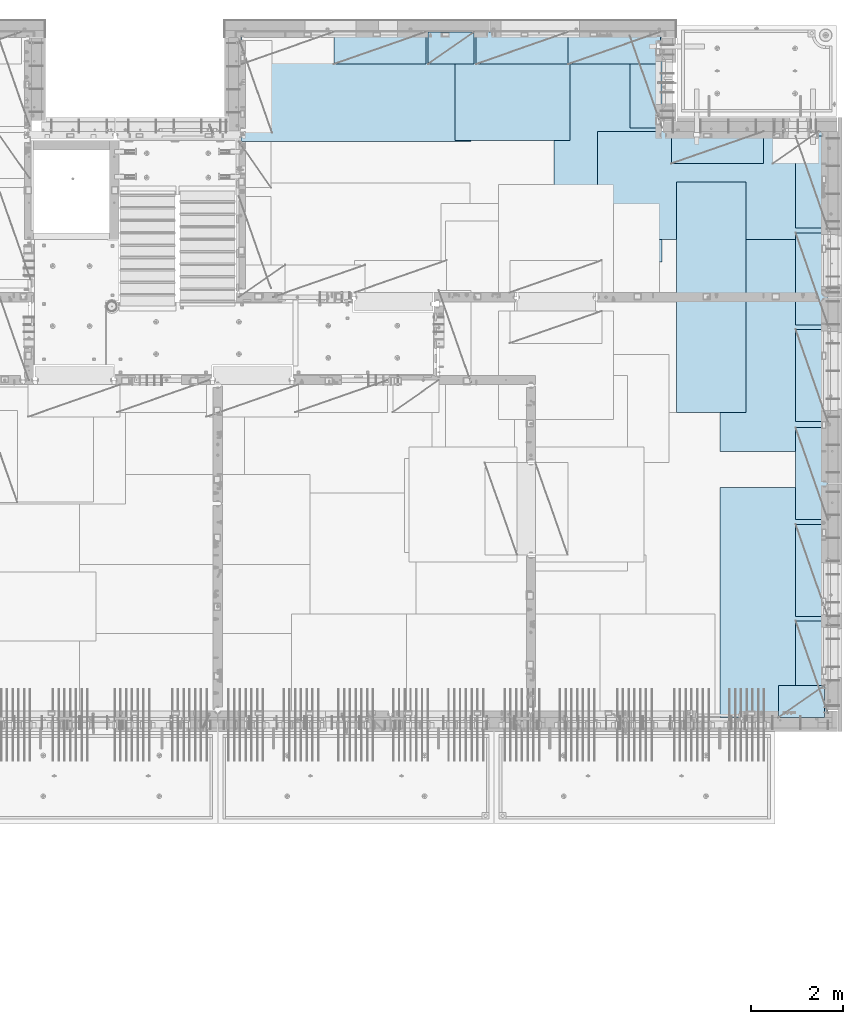
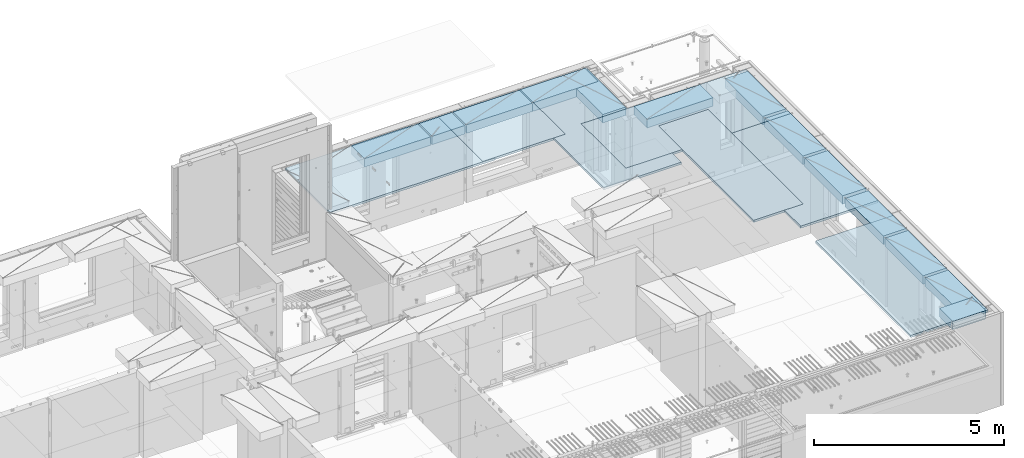
# One storey, part 211 of 352: 20 plates, 20 elements without a shape of their own.
"""IFC2X3 building model written with IfcOpenShell, lengths in millimetres."""

from ifc_helpers import new_model, si_unit, frame, origin_with_axes, place, context, subcontext, project, spatial, faceted_brep, material, type_object, element, aggregate, save


model = new_model("IFC2X3")

# Units and contexts
model_context = context("Model", 3, precision=1e-05, world=origin_with_axes())
body_context = subcontext(model_context, "Body", "Model", "MODEL_VIEW")
ifc_project = project(units=[si_unit("LENGTHUNIT", "METRE", prefix="MILLI"), si_unit("AREAUNIT", "SQUARE_METRE"), si_unit("VOLUMEUNIT", "CUBIC_METRE"), si_unit("MASSUNIT", "GRAM", prefix="KILO"), si_unit("TIMEUNIT", "SECOND"), si_unit("PLANEANGLEUNIT", "RADIAN"), si_unit("SOLIDANGLEUNIT", "STERADIAN"), si_unit("THERMODYNAMICTEMPERATUREUNIT", "DEGREE_CELSIUS"), si_unit("LUMINOUSINTENSITYUNIT", "LUMEN")], contexts=[model_context])

# Site, building, storey
site_placement = place(None, origin_with_axes())
site = spatial("IfcSite", under=ifc_project, at=site_placement, CompositionType="ELEMENT")
building_placement = place(site_placement, origin_with_axes())
building = spatial("IfcBuilding", under=site, at=building_placement, CompositionType="ELEMENT")
storey_placement = place(building_placement, origin_with_axes())
storey = spatial("IfcBuildingStorey", under=building, at=storey_placement, Name="6", CompositionType="ELEMENT", Elevation=0.0)

# Assembly, plate
assembly_1_placement = place(storey_placement, origin_with_axes())
assembly_1 = element("IfcElementAssembly", 1, at=assembly_1_placement, inside=storey, Name="Steel Assembly", AssemblyPlace="NOTDEFINED", PredefinedType="NOTDEFINED")
ifc_material = material()
plate_type_1 = type_object("IfcPlateType", PredefinedType="NOTDEFINED")
plate_1_placement = place(assembly_1_placement, frame((26960.07, 22728.45, 99695.1), z_axis=(1.0, 0.0, 0.0), x_axis=(0.0, -1.0, 0.0)))
plate_1 = element("IfcPlate", 2, at=plate_1_placement, type_object=plate_type_1, material=ifc_material, Name="1/2", context=body_context, shape_type="Brep", body=[
    faceted_brep([(0.0, -35.0, 0.0), (0.0, -35.0, 2500.0), (0.0, 35.0, 2500.0), (0.0, 35.0, 0.0), (2349.99951171875, -35.0, 2500.0), (2349.99951171875, 35.0, 2500.0), (2350.0, -35.0, 0.0), (2350.0, 35.0, 0.0)], [[[0, 1, 2, 3]], [[1, 4, 5, 2]], [[4, 6, 7, 5]], [[6, 0, 3, 7]], [[5, 7, 3, 2]], [[6, 4, 1, 0]]]),
])
aggregate(assembly_1, [plate_1])

assembly_2_placement = place(storey_placement, origin_with_axes())
assembly_2 = element("IfcElementAssembly", 3, at=assembly_2_placement, inside=storey, Name="Steel Assembly", AssemblyPlace="NOTDEFINED", PredefinedType="NOTDEFINED")
plate_2_placement = place(assembly_2_placement, frame((22309.9998779297, 22710.0009765625, 99695.1), z_axis=(1.0, 0.0, 0.0), x_axis=(0.0, -1.0, 0.0)))
plate_2 = element("IfcPlate", 4, at=plate_2_placement, type_object=plate_type_1, material=ifc_material, context=body_context, shape_type="Brep", body=[
    faceted_brep([(0.0, -35.0, 0.0), (0.0, -35.0, 5000.0), (0.0, 35.0, 5000.0), (0.0, 35.0, 0.0), (2349.99951171875, -35.0, 5000.0), (2349.99951171875, 35.0, 5000.0), (2350.0, -35.0, 0.0), (2350.0, 35.0, 0.0)], [[[0, 1, 2, 3]], [[1, 4, 5, 2]], [[4, 6, 7, 5]], [[6, 0, 3, 7]], [[5, 7, 3, 2]], [[6, 4, 1, 0]]]),
])
aggregate(assembly_2, [plate_2])

assembly_3_placement = place(storey_placement, origin_with_axes())
assembly_3 = element("IfcElementAssembly", 5, at=assembly_3_placement, inside=storey, Name="Steel Assembly", AssemblyPlace="NOTDEFINED", PredefinedType="NOTDEFINED")
plate_3_placement = place(assembly_3_placement, frame((31460.0, 22740.0, 99695.1), z_axis=(0.0, -1.0, 0.0), x_axis=(-1.0, 3.00000001838171e-08, 0.0)))
plate_3 = element("IfcPlate", 6, at=plate_3_placement, type_object=plate_type_1, material=ifc_material, context=body_context, shape_type="Brep", body=[
    faceted_brep([(0.0, -35.0, 0.0), (0.0, -35.0, 5000.0), (0.0, 35.0, 5000.0), (0.0, 35.0, 0.0), (2349.99951171875, -35.0, 5000.0), (2349.99951171875, 35.0, 5000.0), (2350.0, -35.0, 0.0), (2350.0, 35.0, 0.0)], [[[0, 1, 2, 3]], [[1, 4, 5, 2]], [[4, 6, 7, 5]], [[6, 0, 3, 7]], [[5, 7, 3, 2]], [[6, 4, 1, 0]]]),
])
aggregate(assembly_3, [plate_3])

assembly_4_placement = place(storey_placement, origin_with_axes())
assembly_4 = element("IfcElementAssembly", 7, at=assembly_4_placement, inside=storey, Name="Steel Assembly", AssemblyPlace="NOTDEFINED", PredefinedType="NOTDEFINED")
plate_4_placement = place(assembly_4_placement, frame((35060.0, 12850.0, 99695.1), z_axis=(0.0, -1.0, 0.0), x_axis=(-1.0, 3.00000001838171e-08, 0.0)))
plate_4 = element("IfcPlate", 8, at=plate_4_placement, type_object=plate_type_1, material=ifc_material, context=body_context, shape_type="Brep", body=[
    faceted_brep([(0.0, -35.0, 0.0), (0.0, -35.0, 5000.0), (0.0, 35.0, 5000.0), (0.0, 35.0, 0.0), (2349.99951171875, -35.0, 5000.0), (2349.99951171875, 35.0, 5000.0), (2350.0, -35.0, 0.0), (2350.0, 35.0, 0.0)], [[[0, 1, 2, 3]], [[1, 4, 5, 2]], [[4, 6, 7, 5]], [[6, 0, 3, 7]], [[5, 7, 3, 2]], [[6, 4, 1, 0]]]),
])
aggregate(assembly_4, [plate_4])

assembly_5_placement = place(storey_placement, origin_with_axes())
assembly_5 = element("IfcElementAssembly", 9, at=assembly_5_placement, inside=storey, Name="Steel Assembly", AssemblyPlace="NOTDEFINED", PredefinedType="NOTDEFINED")
plate_5_placement = place(assembly_5_placement, frame((35060.0, 18630.0, 99695.1), z_axis=(0.0, -1.0, 0.0), x_axis=(-1.0, 3.00000001838171e-08, 0.0)))
plate_5 = element("IfcPlate", 10, at=plate_5_placement, type_object=plate_type_1, material=ifc_material, context=body_context, shape_type="Brep", body=[
    faceted_brep([(0.0, -35.0, 0.0), (0.0, -35.0, 5000.0), (0.0, 35.0, 5000.0), (0.0, 35.0, 0.0), (2349.99951171875, -35.0, 5000.0), (2349.99951171875, 35.0, 5000.0), (2350.0, -35.0, 0.0), (2350.0, 35.0, 0.0)], [[[0, 1, 2, 3]], [[1, 4, 5, 2]], [[4, 6, 7, 5]], [[6, 0, 3, 7]], [[5, 7, 3, 2]], [[6, 4, 1, 0]]]),
])
aggregate(assembly_5, [plate_5])

assembly_6_placement = place(storey_placement, origin_with_axes())
assembly_6 = element("IfcElementAssembly", 11, at=assembly_6_placement, inside=storey, Name="Steel Assembly", AssemblyPlace="NOTDEFINED", PredefinedType="NOTDEFINED")
plate_6_placement = place(assembly_6_placement, frame((30060.0, 20580.0, 99695.1), z_axis=(1.0, 0.0, 0.0), x_axis=(0.0, -1.0, 0.0)))
plate_6 = element("IfcPlate", 12, at=plate_6_placement, type_object=plate_type_1, material=ifc_material, context=body_context, shape_type="Brep", body=[
    faceted_brep([(0.0, -35.0, 0.0), (0.0, -35.0, 5000.0), (0.0, 35.0, 5000.0), (0.0, 35.0, 0.0), (2349.99951171875, -35.0, 5000.0), (2349.99951171875, 35.0, 5000.0), (2350.0, -35.0, 0.0), (2350.0, 35.0, 0.0)], [[[0, 1, 2, 3]], [[1, 4, 5, 2]], [[4, 6, 7, 5]], [[6, 0, 3, 7]], [[5, 7, 3, 2]], [[6, 4, 1, 0]]]),
])
aggregate(assembly_6, [plate_6])

assembly_7_placement = place(storey_placement, origin_with_axes())
assembly_7 = element("IfcElementAssembly", 13, at=assembly_7_placement, inside=storey, Name="Steel Assembly", AssemblyPlace="NOTDEFINED", PredefinedType="NOTDEFINED")
plate_type_2 = type_object("IfcPlateType", PredefinedType="NOTDEFINED")
plate_7_placement = place(assembly_7_placement, frame((33275.0000122641, 19480.0, 99695.1000003815), z_axis=(0.0, -1.0, 0.0), x_axis=(-1.0, 3.00000001838171e-08, 0.0)))
plate_7 = element("IfcPlate", 14, at=plate_7_placement, type_object=plate_type_2, material=ifc_material, context=body_context, shape_type="Brep", body=[
    faceted_brep([(0.0, -35.0, 0.0), (0.0, -35.0, 5000.0), (0.0, 35.0, 5000.0), (0.0, 35.0, 0.0), (1499.99951171875, -35.0, 5000.0), (1499.99951171875, 35.0, 5000.0), (1500.0, -35.0, 0.0), (1500.0, 35.0, 0.0)], [[[0, 1, 2, 3]], [[1, 4, 5, 2]], [[4, 6, 7, 5]], [[6, 0, 3, 7]], [[5, 7, 3, 2]], [[6, 4, 1, 0]]]),
])
aggregate(assembly_7, [plate_7])

assembly_8_placement = place(storey_placement, origin_with_axes())
assembly_8 = element("IfcElementAssembly", 15, at=assembly_8_placement, inside=storey, Name="Steel Assembly", AssemblyPlace="NOTDEFINED", PredefinedType="NOTDEFINED")
plate_type_3 = type_object("IfcPlateType", PredefinedType="NOTDEFINED")
plate_8_placement = place(assembly_8_placement, frame((31420.0, 22740.0001220703, 99595.3), z_axis=(0.0, -1.0, 0.0), x_axis=(-1.0, 3.00000001838171e-08, 0.0)))
plate_8 = element("IfcPlate", 16, at=plate_8_placement, type_object=plate_type_3, material=ifc_material, Name="RE1", context=body_context, shape_type="Brep", body=[
    faceted_brep([(1.81898940354586e-12, -135.0, 1.81898940354586e-12), (0.0, -135.0, 699.999999999996), (0.0, 135.0, 699.999999999996), (1.81898940354586e-12, 135.0, 1.81898940354586e-12), (1999.99951171875, -135.0, 699.999999999993), (1999.99951171875, 135.0, 699.999999999993), (2000.0, -135.0, -3.63797880709171e-12), (2000.0, 135.0, -3.63797880709171e-12)], [[[0, 1, 2, 3]], [[1, 4, 5, 2]], [[4, 6, 7, 5]], [[6, 0, 3, 7]], [[5, 7, 3, 2]], [[6, 4, 1, 0]]]),
])
aggregate(assembly_8, [plate_8])

assembly_9_placement = place(storey_placement, origin_with_axes())
assembly_9 = element("IfcElementAssembly", 17, at=assembly_9_placement, inside=storey, Name="Steel Assembly", AssemblyPlace="NOTDEFINED", PredefinedType="NOTDEFINED")
plate_9_placement = place(assembly_9_placement, frame((33985.0, 7849.99999992931, 99595.3), z_axis=(0.0, 1.0, 0.0), x_axis=(1.0, 0.0, 0.0)))
plate_9 = element("IfcPlate", 18, at=plate_9_placement, type_object=plate_type_3, material=ifc_material, Name="RE1_1/2", context=body_context, shape_type="Brep", body=[
    faceted_brep([(1.81898940354586e-12, -135.0, 1.81898940354586e-12), (0.0, -135.0, 699.999999999996), (0.0, 135.0, 699.999999999996), (1.81898940354586e-12, 135.0, 1.81898940354586e-12), (999.99951171875, -135.0, 700.0), (999.99951171875, 135.0, 700.0), (1000.0, -135.0, 0.0), (1000.0, 135.0, 0.0)], [[[0, 1, 2, 3]], [[1, 4, 5, 2]], [[4, 6, 7, 5]], [[6, 0, 3, 7]], [[5, 7, 3, 2]], [[6, 4, 1, 0]]]),
])
aggregate(assembly_9, [plate_9])

assembly_10_placement = place(storey_placement, origin_with_axes())
assembly_10 = element("IfcElementAssembly", 19, at=assembly_10_placement, inside=storey, Name="Steel Assembly", AssemblyPlace="NOTDEFINED", PredefinedType="NOTDEFINED")
plate_10_placement = place(assembly_10_placement, frame((35060.0001220703, 14280.0, 99595.3), z_axis=(-1.0, 3.00000001838171e-08, 0.0), x_axis=(0.0, 1.0, 0.0)))
plate_10 = element("IfcPlate", 20, at=plate_10_placement, type_object=plate_type_3, material=ifc_material, Name="RE1", context=body_context, shape_type="Brep", body=[
    faceted_brep([(1.81898940354586e-12, -135.0, 1.81898940354586e-12), (0.0, -135.0, 699.999999999996), (0.0, 135.0, 699.999999999996), (1.81898940354586e-12, 135.0, 1.81898940354586e-12), (1999.99951171875, -135.0, 699.999999999993), (1999.99951171875, 135.0, 699.999999999993), (2000.0, -135.0, -3.63797880709171e-12), (2000.0, 135.0, -3.63797880709171e-12)], [[[0, 1, 2, 3]], [[1, 4, 5, 2]], [[4, 6, 7, 5]], [[6, 0, 3, 7]], [[5, 7, 3, 2]], [[6, 4, 1, 0]]]),
])
aggregate(assembly_10, [plate_10])

assembly_11_placement = place(storey_placement, origin_with_axes())
assembly_11 = element("IfcElementAssembly", 21, at=assembly_11_placement, inside=storey, Name="Steel Assembly", AssemblyPlace="NOTDEFINED", PredefinedType="NOTDEFINED")
plate_11_placement = place(assembly_11_placement, frame((35060.0001220703, 16380.0, 99595.3), z_axis=(-1.0, 3.00000001838171e-08, 0.0), x_axis=(0.0, 1.0, 0.0)))
plate_11 = element("IfcPlate", 22, at=plate_11_placement, type_object=plate_type_3, material=ifc_material, Name="RE1", context=body_context, shape_type="Brep", body=[
    faceted_brep([(1.81898940354586e-12, -135.0, 1.81898940354586e-12), (0.0, -135.0, 699.999999999996), (0.0, 135.0, 699.999999999996), (1.81898940354586e-12, 135.0, 1.81898940354586e-12), (1999.99951171875, -135.0, 699.999999999993), (1999.99951171875, 135.0, 699.999999999993), (2000.0, -135.0, -3.63797880709171e-12), (2000.0, 135.0, -3.63797880709171e-12)], [[[0, 1, 2, 3]], [[1, 4, 5, 2]], [[4, 6, 7, 5]], [[6, 0, 3, 7]], [[5, 7, 3, 2]], [[6, 4, 1, 0]]]),
])
aggregate(assembly_11, [plate_11])

assembly_12_placement = place(storey_placement, origin_with_axes())
assembly_12 = element("IfcElementAssembly", 23, at=assembly_12_placement, inside=storey, Name="Steel Assembly", AssemblyPlace="NOTDEFINED", PredefinedType="NOTDEFINED")
plate_12_placement = place(assembly_12_placement, frame((35060.0001220703, 18480.0, 99595.3), z_axis=(-1.0, 3.00000001838171e-08, 0.0), x_axis=(0.0, 1.0, 0.0)))
plate_12 = element("IfcPlate", 24, at=plate_12_placement, type_object=plate_type_3, material=ifc_material, Name="RE1", context=body_context, shape_type="Brep", body=[
    faceted_brep([(1.81898940354586e-12, -135.0, 1.81898940354586e-12), (0.0, -135.0, 699.999999999996), (0.0, 135.0, 699.999999999996), (1.81898940354586e-12, 135.0, 1.81898940354586e-12), (1999.99951171875, -135.0, 699.999999999993), (1999.99951171875, 135.0, 699.999999999993), (2000.0, -135.0, -3.63797880709171e-12), (2000.0, 135.0, -3.63797880709171e-12)], [[[0, 1, 2, 3]], [[1, 4, 5, 2]], [[4, 6, 7, 5]], [[6, 0, 3, 7]], [[5, 7, 3, 2]], [[6, 4, 1, 0]]]),
])
aggregate(assembly_12, [plate_12])

assembly_13_placement = place(storey_placement, origin_with_axes())
assembly_13 = element("IfcElementAssembly", 25, at=assembly_13_placement, inside=storey, Name="Steel Assembly", AssemblyPlace="NOTDEFINED", PredefinedType="NOTDEFINED")
plate_13_placement = place(assembly_13_placement, frame((35060.0001220703, 12150.0, 99595.3), z_axis=(-1.0, 3.00000001838171e-08, 0.0), x_axis=(0.0, 1.0, 0.0)))
plate_13 = element("IfcPlate", 26, at=plate_13_placement, type_object=plate_type_3, material=ifc_material, Name="RE1", context=body_context, shape_type="Brep", body=[
    faceted_brep([(1.81898940354586e-12, -135.0, 1.81898940354586e-12), (0.0, -135.0, 699.999999999996), (0.0, 135.0, 699.999999999996), (1.81898940354586e-12, 135.0, 1.81898940354586e-12), (1999.99951171875, -135.0, 699.999999999993), (1999.99951171875, 135.0, 699.999999999993), (2000.0, -135.0, -3.63797880709171e-12), (2000.0, 135.0, -3.63797880709171e-12)], [[[0, 1, 2, 3]], [[1, 4, 5, 2]], [[4, 6, 7, 5]], [[6, 0, 3, 7]], [[5, 7, 3, 2]], [[6, 4, 1, 0]]]),
])
aggregate(assembly_13, [plate_13])

assembly_14_placement = place(storey_placement, origin_with_axes())
assembly_14 = element("IfcElementAssembly", 27, at=assembly_14_placement, inside=storey, Name="Steel Assembly", AssemblyPlace="NOTDEFINED", PredefinedType="NOTDEFINED")
plate_14_placement = place(assembly_14_placement, frame((35060.0001220703, 10050.0, 99595.3), z_axis=(-1.0, 3.00000001838171e-08, 0.0), x_axis=(0.0, 1.0, 0.0)))
plate_14 = element("IfcPlate", 28, at=plate_14_placement, type_object=plate_type_3, material=ifc_material, Name="RE1", context=body_context, shape_type="Brep", body=[
    faceted_brep([(1.81898940354586e-12, -135.0, 1.81898940354586e-12), (0.0, -135.0, 699.999999999996), (0.0, 135.0, 699.999999999996), (1.81898940354586e-12, 135.0, 1.81898940354586e-12), (1999.99951171875, -135.0, 699.999999999993), (1999.99951171875, 135.0, 699.999999999993), (2000.0, -135.0, -3.63797880709171e-12), (2000.0, 135.0, -3.63797880709171e-12)], [[[0, 1, 2, 3]], [[1, 4, 5, 2]], [[4, 6, 7, 5]], [[6, 0, 3, 7]], [[5, 7, 3, 2]], [[6, 4, 1, 0]]]),
])
aggregate(assembly_14, [plate_14])

assembly_15_placement = place(storey_placement, origin_with_axes())
assembly_15 = element("IfcElementAssembly", 29, at=assembly_15_placement, inside=storey, Name="Steel Assembly", AssemblyPlace="NOTDEFINED", PredefinedType="NOTDEFINED")
plate_15_placement = place(assembly_15_placement, frame((35060.0001220703, 7950.0, 99595.3), z_axis=(-1.0, 3.00000001838171e-08, 0.0), x_axis=(0.0, 1.0, 0.0)))
plate_15 = element("IfcPlate", 30, at=plate_15_placement, type_object=plate_type_3, material=ifc_material, Name="RE1", context=body_context, shape_type="Brep", body=[
    faceted_brep([(1.81898940354586e-12, -135.0, 1.81898940354586e-12), (0.0, -135.0, 699.999999999996), (0.0, 135.0, 699.999999999996), (1.81898940354586e-12, 135.0, 1.81898940354586e-12), (1999.99951171875, -135.0, 699.999999999993), (1999.99951171875, 135.0, 699.999999999993), (2000.0, -135.0, -3.63797880709171e-12), (2000.0, 135.0, -3.63797880709171e-12)], [[[0, 1, 2, 3]], [[1, 4, 5, 2]], [[4, 6, 7, 5]], [[6, 0, 3, 7]], [[5, 7, 3, 2]], [[6, 4, 1, 0]]]),
])
aggregate(assembly_15, [plate_15])

assembly_16_placement = place(storey_placement, origin_with_axes())
assembly_16 = element("IfcElementAssembly", 31, at=assembly_16_placement, inside=storey, Name="Steel Assembly", AssemblyPlace="NOTDEFINED", PredefinedType="NOTDEFINED")
plate_16_placement = place(assembly_16_placement, frame((33660.0, 20580.0001220703, 99595.3), z_axis=(0.0, -1.0, 0.0), x_axis=(-1.0, 3.00000001838171e-08, 0.0)))
plate_16 = element("IfcPlate", 32, at=plate_16_placement, type_object=plate_type_3, material=ifc_material, Name="RE1", context=body_context, shape_type="Brep", body=[
    faceted_brep([(1.81898940354586e-12, -135.0, 1.81898940354586e-12), (0.0, -135.0, 699.999999999996), (0.0, 135.0, 699.999999999996), (1.81898940354586e-12, 135.0, 1.81898940354586e-12), (1999.99951171875, -135.0, 699.999999999993), (1999.99951171875, 135.0, 699.999999999993), (2000.0, -135.0, -3.63797880709171e-12), (2000.0, 135.0, -3.63797880709171e-12)], [[[0, 1, 2, 3]], [[1, 4, 5, 2]], [[4, 6, 7, 5]], [[6, 0, 3, 7]], [[5, 7, 3, 2]], [[6, 4, 1, 0]]]),
])
aggregate(assembly_16, [plate_16])

assembly_17_placement = place(storey_placement, origin_with_axes())
assembly_17 = element("IfcElementAssembly", 33, at=assembly_17_placement, inside=storey, Name="Steel Assembly", AssemblyPlace="NOTDEFINED", PredefinedType="NOTDEFINED")
plate_17_placement = place(assembly_17_placement, frame((31460.0001220703, 20660.0, 99595.3), z_axis=(-1.0, 3.00000001838171e-08, 0.0), x_axis=(0.0, 1.0, 0.0)))
plate_17 = element("IfcPlate", 34, at=plate_17_placement, type_object=plate_type_3, material=ifc_material, Name="RE1", context=body_context, shape_type="Brep", body=[
    faceted_brep([(1.81898940354586e-12, -135.0, 1.81898940354586e-12), (0.0, -135.0, 699.999999999996), (0.0, 135.0, 699.999999999996), (1.81898940354586e-12, 135.0, 1.81898940354586e-12), (1999.99951171875, -135.0, 699.999999999993), (1999.99951171875, 135.0, 699.999999999993), (2000.0, -135.0, -3.63797880709171e-12), (2000.0, 135.0, -3.63797880709171e-12)], [[[0, 1, 2, 3]], [[1, 4, 5, 2]], [[4, 6, 7, 5]], [[6, 0, 3, 7]], [[5, 7, 3, 2]], [[6, 4, 1, 0]]]),
])
aggregate(assembly_17, [plate_17])

assembly_18_placement = place(storey_placement, origin_with_axes())
assembly_18 = element("IfcElementAssembly", 35, at=assembly_18_placement, inside=storey, Name="Steel Assembly", AssemblyPlace="NOTDEFINED", PredefinedType="NOTDEFINED")
plate_18_placement = place(assembly_18_placement, frame((26330.0, 22740.0001220703, 99595.3), z_axis=(0.0, -1.0, 0.0), x_axis=(-1.0, 3.00000001838171e-08, 0.0)))
plate_18 = element("IfcPlate", 36, at=plate_18_placement, type_object=plate_type_3, material=ifc_material, Name="RE1", context=body_context, shape_type="Brep", body=[
    faceted_brep([(1.81898940354586e-12, -135.0, 1.81898940354586e-12), (0.0, -135.0, 699.999999999996), (0.0, 135.0, 699.999999999996), (1.81898940354586e-12, 135.0, 1.81898940354586e-12), (1999.99951171875, -135.0, 699.999999999993), (1999.99951171875, 135.0, 699.999999999993), (2000.0, -135.0, -3.63797880709171e-12), (2000.0, 135.0, -3.63797880709171e-12)], [[[0, 1, 2, 3]], [[1, 4, 5, 2]], [[4, 6, 7, 5]], [[6, 0, 3, 7]], [[5, 7, 3, 2]], [[6, 4, 1, 0]]]),
])
aggregate(assembly_18, [plate_18])

assembly_19_placement = place(storey_placement, origin_with_axes())
assembly_19 = element("IfcElementAssembly", 37, at=assembly_19_placement, inside=storey, Name="Steel Assembly", AssemblyPlace="NOTDEFINED", PredefinedType="NOTDEFINED")
plate_19_placement = place(assembly_19_placement, frame((29420.0, 22740.0001220703, 99595.3), z_axis=(0.0, -1.0, 0.0), x_axis=(-1.0, 3.00000001838171e-08, 0.0)))
plate_19 = element("IfcPlate", 38, at=plate_19_placement, type_object=plate_type_3, material=ifc_material, Name="RE1", context=body_context, shape_type="Brep", body=[
    faceted_brep([(1.81898940354586e-12, -135.0, 1.81898940354586e-12), (0.0, -135.0, 699.999999999996), (0.0, 135.0, 699.999999999996), (1.81898940354586e-12, 135.0, 1.81898940354586e-12), (1999.99951171875, -135.0, 699.999999999993), (1999.99951171875, 135.0, 699.999999999993), (2000.0, -135.0, -3.63797880709171e-12), (2000.0, 135.0, -3.63797880709171e-12)], [[[0, 1, 2, 3]], [[1, 4, 5, 2]], [[4, 6, 7, 5]], [[6, 0, 3, 7]], [[5, 7, 3, 2]], [[6, 4, 1, 0]]]),
])
aggregate(assembly_19, [plate_19])

assembly_20_placement = place(storey_placement, origin_with_axes())
assembly_20 = element("IfcElementAssembly", 39, at=assembly_20_placement, inside=storey, Name="Steel Assembly", AssemblyPlace="NOTDEFINED", PredefinedType="NOTDEFINED")
plate_20_placement = place(assembly_20_placement, frame((27375.0, 22740.0000000707, 99595.3), z_axis=(0.0, -1.0, 0.0), x_axis=(-1.0, 3.00000001838171e-08, 0.0)))
plate_20 = element("IfcPlate", 40, at=plate_20_placement, type_object=plate_type_3, material=ifc_material, Name="RE1_1/2", context=body_context, shape_type="Brep", body=[
    faceted_brep([(1.81898940354586e-12, -135.0, 1.81898940354586e-12), (0.0, -135.0, 699.999999999996), (0.0, 135.0, 699.999999999996), (1.81898940354586e-12, 135.0, 1.81898940354586e-12), (999.99951171875, -135.0, 700.0), (999.99951171875, 135.0, 700.0), (1000.0, -135.0, 0.0), (1000.0, 135.0, 0.0)], [[[0, 1, 2, 3]], [[1, 4, 5, 2]], [[4, 6, 7, 5]], [[6, 0, 3, 7]], [[5, 7, 3, 2]], [[6, 4, 1, 0]]]),
])
aggregate(assembly_20, [plate_20])

save(model, "model.ifc")
